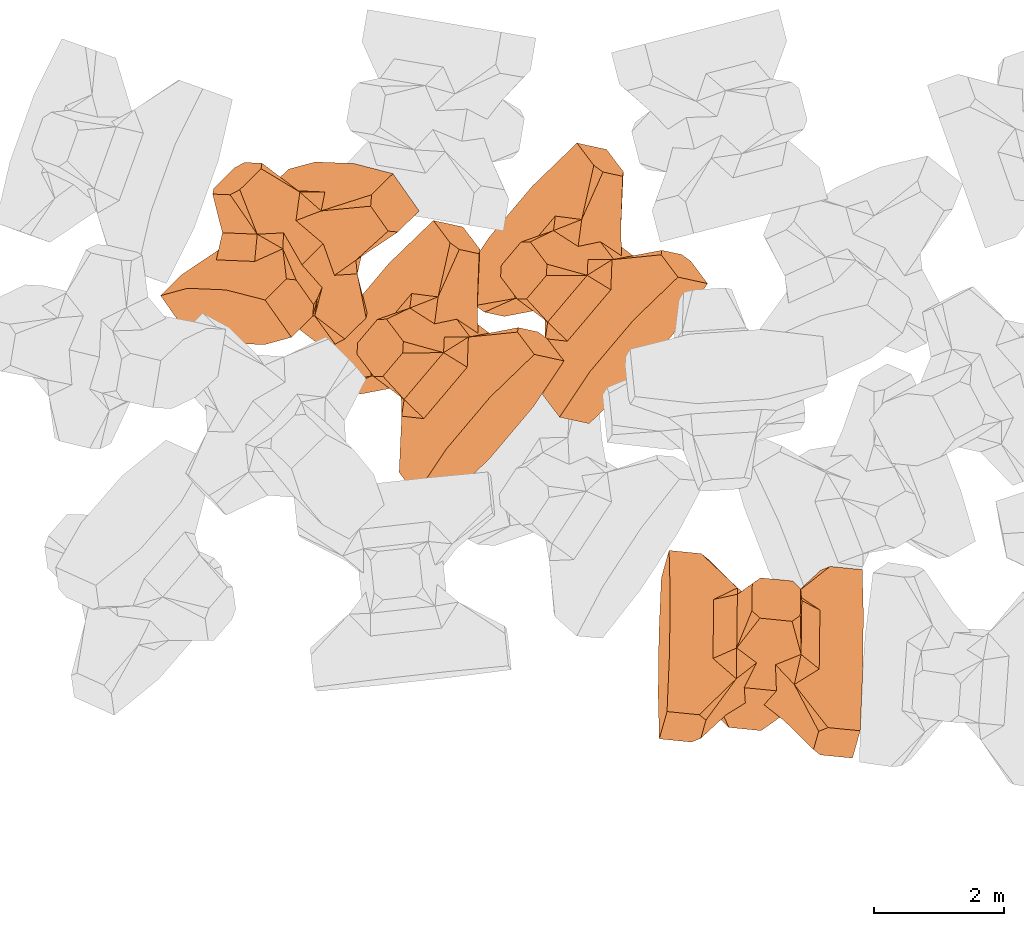
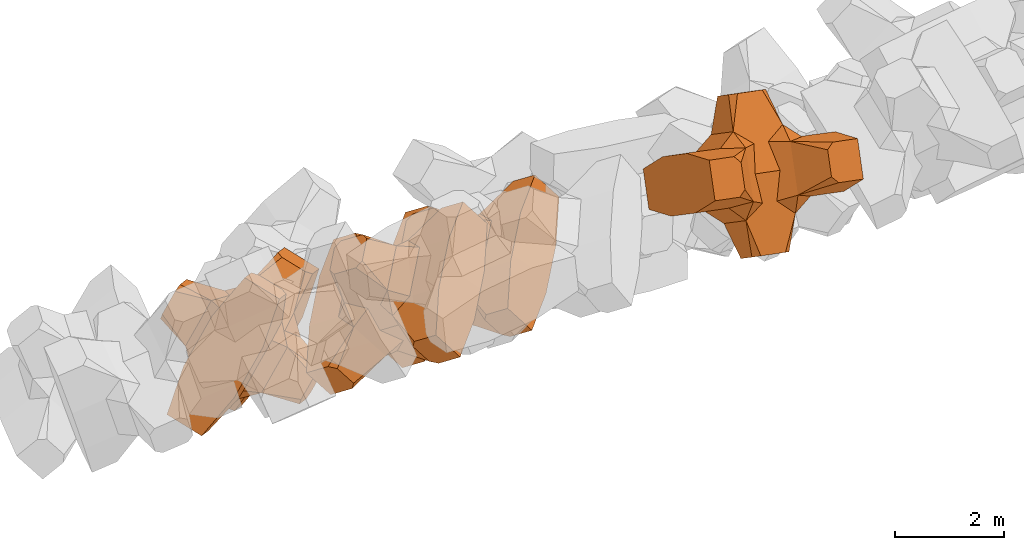
# One storey, part 12 of 17: 4 civil elements.
"""IFC4 building model written with IfcOpenShell, lengths in metres."""

from ifc_helpers import new_model, entity, si_unit, converted_unit, frame, origin_with_axes, origin_2d_with_axis, place, context, subcontext, project, spatial, polygons, element, save


model = new_model("IFC4")

# Units and contexts
model_context = context("Model", 3, precision=1e-05, world=origin_with_axes())
plan_context = context("Plan", 2, precision=1e-05, world=origin_2d_with_axis())
body_context = subcontext(model_context, "Body", "Model", "MODEL_VIEW")
ifc_project = project(units=[si_unit("VOLUMEUNIT", "CUBIC_METRE"), si_unit("LENGTHUNIT", "METRE"), converted_unit("PLANEANGLEUNIT", "degree", entity("IfcReal", 0.0174532925199433), si_unit("PLANEANGLEUNIT", "RADIAN"), dimensions=[0, 0, 0, 0, 0, 0, 0]), si_unit("AREAUNIT", "SQUARE_METRE")], contexts=[model_context, plan_context])

# Site, building, storey
site_placement = place(None, origin_with_axes())
site = spatial("IfcSite", under=ifc_project, at=site_placement)
building_placement = place(site_placement, origin_with_axes())
building = spatial("IfcBuilding", under=site, at=building_placement, Name="Building")
storey_placement = place(building_placement, origin_with_axes())
storey = spatial("IfcBuildingStorey", under=building, at=storey_placement, Name="Storey")

# Civil elements
civil_element_1_placement = place(storey_placement, frame((3.9119188785553, 18.5818061828613, 3.0172381401062), z_axis=(0.536796321599093, -0.763146803742509, -0.359800868613843), x_axis=(-0.534454296596476, 0.0224108085713021, -0.844900207426147)))
element("IfcCivilElement", 1, at=civil_element_1_placement, inside=storey, ObjectType="IfcCivilElementType", context=body_context, shape_type="Tessellation", body=[
    polygons([(0.50000011920929, 0.500000059604645, 0.821428716182709), (0.374999821186066, 0.249999940395355, 1.50000023841858), (0.550000011920929, 0.145680621266365, 0.550000131130219), (0.374999821186066, -0.250000029802322, 1.50000023841858), (0.651315808296204, -0.250000029802322, 1.45970560083697e-07), (0.651315808296204, 0.249999940395355, 1.45970560083697e-07), (0.550000011920929, -0.145680695772171, 0.550000131130219), (0.50000011920929, -0.500000059604645, 0.821428716182709), (-0.25, 0.374999791383743, 1.50000023841858), (0.249999970197678, 0.374999791383743, 1.50000023841858), (-0.500000059604645, 0.500000059604645, 0.821428716182709), (-0.550000011920929, 0.824999988079071, 0.550000131130219), (0.550000011920929, 0.824999988079071, 0.550000131130219), (-0.550000011920929, 1.5, 0.550000131130219), (0.550000011920929, 1.5, 0.550000131130219), (-0.25, -0.375, 1.50000023841858), (0.249999970197678, -0.375, 1.50000023841858), (-0.374999970197678, -0.250000029802322, 1.50000023841858), (-0.374999970197678, 0.249999940395355, 1.50000023841858), (1.5, 0.87499988079071, -0.249999836087227), (1.5, 0.87499988079071, 0.25000011920929), (0.845557510852814, 0.449999898672104, -0.49555516242981), (0.845557510852814, 0.449999898672104, 0.49555516242981), (1.5, 1.5, -0.374999821186066), (1.5, 1.5, 0.374999970197678), (1.5, 1.0, -0.374999821186066), (1.5, 1.0, 0.374999970197678), (-1.5, 1.5, -0.374999821186066), (-1.5, 1.5, 0.374999970197678), (-0.550000011920929, 1.5, -0.549999833106995), (0.550000011920929, 1.5, -0.549999833106995), (0.550000011920929, 0.145680621266365, -0.549999833106995), (-0.500000059604645, -0.500000059604645, 0.821428716182709), (-0.550000011920929, -0.145680695772171, 0.550000131130219), (-0.651315808296204, 0.249999940395355, 1.45970560083697e-07), (-0.651315808296204, -0.250000029802322, 1.45970560083697e-07), (-0.550000011920929, 0.145680621266365, 0.550000131130219), (-1.5, 0.87499988079071, 0.25000011920929), (-1.5, 0.87499988079071, -0.249999836087227), (-0.845557391643524, 0.449999898672104, 0.49555516242981), (-0.845557391643524, 0.449999898672104, -0.49555516242981), (-1.5, 1.0, 0.374999970197678), (-1.5, 1.0, -0.374999821186066), (-0.550000011920929, 0.145680621266365, -0.549999833106995), (0.550000011920929, -0.825000107288361, 0.550000131130219), (-0.550000011920929, -0.825000107288361, 0.550000131130219), (0.550000011920929, -1.5, 0.550000131130219), (-0.550000011920929, -1.5, 0.550000131130219), (1.5, -0.875000059604645, 0.25000011920929), (1.5, -0.875000059604645, -0.249999836087227), (0.845557510852814, -0.450000137090683, 0.49555516242981), (0.845557510852814, -0.450000137090683, -0.49555516242981), (1.5, -1.5, 0.374999970197678), (1.5, -1.5, -0.374999821186066), (1.5, -1.00000011920929, 0.374999970197678), (1.5, -1.00000011920929, -0.374999821186066), (0.550000011920929, -1.5, -0.549999833106995), (-0.550000011920929, -1.5, -0.549999833106995), (-1.5, -1.5, -0.374999821186066), (-1.5, -1.5, 0.374999970197678), (0.550000011920929, -0.145680695772171, -0.549999833106995), (-1.5, -0.875000059604645, -0.249999836087227), (-1.5, -0.875000059604645, 0.25000011920929), (-0.845557391643524, -0.450000137090683, -0.49555516242981), (-0.845557391643524, -0.450000137090683, 0.49555516242981), (-1.5, -1.00000011920929, -0.374999821186066), (-1.5, -1.00000011920929, 0.374999970197678), (-0.550000011920929, -0.145680695772171, -0.549999833106995), (0.50000011920929, -0.500000059604645, -0.821428537368774), (0.374999821186066, -0.250000029802322, -1.49999988079071), (0.374999821186066, 0.249999940395355, -1.49999988079071), (0.50000011920929, 0.500000059604645, -0.821428537368774), (0.249999970197678, 0.374999791383743, -1.49999988079071), (-0.25, 0.374999791383743, -1.49999988079071), (-0.500000059604645, 0.500000059604645, -0.821428537368774), (0.550000011920929, 0.824999988079071, -0.549999833106995), (-0.550000011920929, 0.824999988079071, -0.549999833106995), (0.249999970197678, -0.375, -1.49999988079071), (-0.25, -0.375, -1.49999988079071), (-0.374999970197678, -0.250000029802322, -1.49999988079071), (-0.374999970197678, 0.249999940395355, -1.49999988079071), (-0.500000059604645, -0.500000059604645, -0.821428537368774), (-0.550000011920929, -0.825000107288361, -0.549999833106995), (0.550000011920929, -0.825000107288361, -0.549999833106995)], [[[1, 2, 3]], [[3, 2, 4]], [[5, 6, 7]], [[7, 6, 3]], [[7, 3, 8]], [[8, 3, 4]], [[9, 10, 11]], [[11, 10, 1]], [[12, 13, 14]], [[14, 13, 15]], [[16, 17, 18]], [[18, 17, 4]], [[18, 4, 19]], [[19, 4, 2]], [[19, 2, 9]], [[9, 2, 10]], [[20, 21, 22]], [[22, 21, 23]], [[24, 25, 26]], [[26, 25, 27]], [[26, 27, 20]], [[20, 27, 21]], [[23, 27, 13]], [[13, 27, 25]], [[13, 25, 15]], [[28, 29, 30]], [[30, 29, 14]], [[30, 14, 31]], [[31, 14, 15]], [[31, 15, 24]], [[24, 15, 25]], [[21, 27, 23]], [[2, 1, 10]], [[13, 12, 1]], [[1, 12, 11]], [[13, 1, 23]], [[32, 22, 6]], [[6, 22, 23]], [[6, 23, 3]], [[3, 23, 1]], [[33, 18, 34]], [[34, 18, 19]], [[35, 36, 37]], [[37, 36, 34]], [[37, 34, 11]], [[11, 34, 19]], [[38, 39, 40]], [[40, 39, 41]], [[29, 28, 42]], [[42, 28, 43]], [[42, 43, 38]], [[38, 43, 39]], [[14, 29, 12]], [[12, 29, 42]], [[12, 42, 40]], [[40, 42, 38]], [[9, 11, 19]], [[40, 11, 12]], [[37, 40, 35]], [[35, 40, 41]], [[35, 41, 44]], [[11, 40, 37]], [[17, 16, 8]], [[8, 16, 33]], [[45, 46, 47]], [[47, 46, 48]], [[49, 50, 51]], [[51, 50, 52]], [[53, 54, 55]], [[55, 54, 56]], [[55, 56, 49]], [[49, 56, 50]], [[47, 53, 45]], [[45, 53, 55]], [[45, 55, 51]], [[54, 53, 57]], [[57, 53, 47]], [[57, 47, 58]], [[58, 47, 48]], [[58, 48, 59]], [[59, 48, 60]], [[51, 55, 49]], [[17, 8, 4]], [[46, 45, 33]], [[33, 45, 8]], [[51, 8, 45]], [[7, 51, 5]], [[5, 51, 52]], [[5, 52, 61]], [[8, 51, 7]], [[62, 63, 64]], [[64, 63, 65]], [[59, 60, 66]], [[66, 60, 67]], [[66, 67, 62]], [[62, 67, 63]], [[65, 67, 46]], [[46, 67, 60]], [[46, 60, 48]], [[63, 67, 65]], [[18, 33, 16]], [[46, 33, 65]], [[68, 64, 36]], [[36, 64, 65]], [[36, 65, 34]], [[34, 65, 33]], [[69, 70, 61]], [[61, 70, 71]], [[6, 5, 32]], [[32, 5, 61]], [[32, 61, 72]], [[72, 61, 71]], [[73, 74, 72]], [[72, 74, 75]], [[76, 77, 31]], [[31, 77, 30]], [[78, 79, 70]], [[70, 79, 80]], [[70, 80, 71]], [[71, 80, 81]], [[71, 81, 73]], [[73, 81, 74]], [[31, 24, 76]], [[76, 24, 26]], [[76, 26, 22]], [[22, 26, 20]], [[73, 72, 71]], [[77, 76, 75]], [[75, 76, 72]], [[22, 72, 76]], [[72, 22, 32]], [[75, 81, 44]], [[44, 81, 80]], [[36, 35, 68]], [[68, 35, 44]], [[68, 44, 82]], [[82, 44, 80]], [[41, 43, 77]], [[77, 43, 28]], [[77, 28, 30]], [[39, 43, 41]], [[81, 75, 74]], [[77, 75, 41]], [[44, 41, 75]], [[79, 78, 82]], [[82, 78, 69]], [[83, 84, 58]], [[58, 84, 57]], [[52, 56, 84]], [[84, 56, 54]], [[84, 54, 57]], [[50, 56, 52]], [[70, 69, 78]], [[84, 83, 69]], [[69, 83, 82]], [[84, 69, 52]], [[61, 52, 69]], [[58, 59, 83]], [[83, 59, 66]], [[83, 66, 64]], [[64, 66, 62]], [[79, 82, 80]], [[64, 82, 83]], [[82, 64, 68]]], closed=True),
])
civil_element_2_placement = place(storey_placement, frame((8.40735340118408, 18.1207790374756, 3.29278421401978), z_axis=(0.605860889445885, -0.131685242162894, -0.784596443808115), x_axis=(0.605345729447791, 0.716229860077992, 0.34723383385261)))
element("IfcCivilElement", 2, at=civil_element_2_placement, inside=storey, ObjectType="IfcCivilElementType", context=body_context, shape_type="Tessellation", body=[
    polygons([(0.500000178813934, 0.500001192092896, 0.821429014205933), (0.374999850988388, 0.250000506639481, 1.50000059604645), (0.550000071525574, 0.145680949091911, 0.550000309944153), (0.374999850988388, -0.250000566244125, 1.50000059604645), (0.651315867900848, -0.250000566244125, 1.45970602716261e-07), (0.651315867900848, 0.250000506639481, 1.45970602716261e-07), (0.550000071525574, -0.145681023597717, 0.550000309944153), (0.500000178813934, -0.500001192092896, 0.821429014205933), (-0.250000029802322, 0.37500062584877, 1.50000059604645), (0.249999985098839, 0.37500062584877, 1.50000059604645), (-0.500000059604645, 0.500001192092896, 0.821429014205933), (-0.550000071525574, 0.825001835823059, 0.550000309944153), (0.550000071525574, 0.825001835823059, 0.550000309944153), (-0.550000071525574, 1.5000034570694, 0.550000309944153), (0.550000071525574, 1.5000034570694, 0.550000309944153), (-0.250000029802322, -0.375000864267349, 1.50000059604645), (0.249999985098839, -0.375000864267349, 1.50000059604645), (-0.375, -0.250000566244125, 1.50000059604645), (-0.375, 0.250000506639481, 1.50000059604645), (1.50000023841858, 0.875001847743988, -0.249999910593033), (1.50000023841858, 0.875001847743988, 0.250000208616257), (0.845557630062103, 0.450000911951065, -0.495555311441422), (0.845557630062103, 0.450000911951065, 0.495555311441422), (1.50000023841858, 1.5000034570694, -0.374999940395355), (1.50000023841858, 1.5000034570694, 0.375000089406967), (1.50000023841858, 1.0000022649765, -0.374999940395355), (1.50000023841858, 1.0000022649765, 0.375000089406967), (-1.50000023841858, 1.5000034570694, -0.374999940395355), (-1.50000023841858, 1.5000034570694, 0.375000089406967), (-0.550000071525574, 1.5000034570694, -0.550000011920929), (0.550000071525574, 1.5000034570694, -0.550000011920929), (0.550000071525574, 0.145680949091911, -0.550000011920929), (-0.500000059604645, -0.500001192092896, 0.821429014205933), (-0.550000071525574, -0.145681023597717, 0.550000309944153), (-0.651315867900848, 0.250000506639481, 1.45970602716261e-07), (-0.651315867900848, -0.250000566244125, 1.45970602716261e-07), (-0.550000071525574, 0.145680949091911, 0.550000309944153), (-1.50000023841858, 0.875001847743988, 0.250000208616257), (-1.50000023841858, 0.875001847743988, -0.249999910593033), (-0.845557451248169, 0.450000911951065, 0.495555311441422), (-0.845557451248169, 0.450000911951065, -0.495555311441422), (-1.50000023841858, 1.0000022649765, 0.375000089406967), (-1.50000023841858, 1.0000022649765, -0.374999940395355), (-0.550000071525574, 0.145680949091911, -0.550000011920929), (0.550000071525574, -0.825001955032349, 0.550000309944153), (-0.550000071525574, -0.825001955032349, 0.550000309944153), (0.550000071525574, -1.5000034570694, 0.550000309944153), (-0.550000071525574, -1.5000034570694, 0.550000309944153), (1.50000023841858, -0.875002026557922, 0.250000208616257), (1.50000023841858, -0.875002026557922, -0.249999910593033), (0.845557630062103, -0.450001120567322, 0.495555311441422), (0.845557630062103, -0.450001120567322, -0.495555311441422), (1.50000023841858, -1.5000034570694, 0.375000089406967), (1.50000023841858, -1.5000034570694, -0.374999940395355), (1.50000023841858, -1.00000238418579, 0.375000089406967), (1.50000023841858, -1.00000238418579, -0.374999940395355), (0.550000071525574, -1.5000034570694, -0.550000011920929), (-0.550000071525574, -1.5000034570694, -0.550000011920929), (-1.50000023841858, -1.5000034570694, -0.374999940395355), (-1.50000023841858, -1.5000034570694, 0.375000089406967), (0.550000071525574, -0.145681023597717, -0.550000011920929), (-1.50000023841858, -0.875002026557922, -0.249999910593033), (-1.50000023841858, -0.875002026557922, 0.250000208616257), (-0.845557451248169, -0.450001120567322, -0.495555311441422), (-0.845557451248169, -0.450001120567322, 0.495555311441422), (-1.50000023841858, -1.00000238418579, -0.374999940395355), (-1.50000023841858, -1.00000238418579, 0.375000089406967), (-0.550000071525574, -0.145681023597717, -0.550000011920929), (0.500000178813934, -0.500001192092896, -0.821428775787354), (0.374999850988388, -0.250000566244125, -1.50000035762787), (0.374999850988388, 0.250000506639481, -1.50000035762787), (0.500000178813934, 0.500001192092896, -0.821428775787354), (0.249999985098839, 0.37500062584877, -1.50000035762787), (-0.250000029802322, 0.37500062584877, -1.50000035762787), (-0.500000059604645, 0.500001192092896, -0.821428775787354), (0.550000071525574, 0.825001835823059, -0.550000011920929), (-0.550000071525574, 0.825001835823059, -0.550000011920929), (0.249999985098839, -0.375000864267349, -1.50000035762787), (-0.250000029802322, -0.375000864267349, -1.50000035762787), (-0.375, -0.250000566244125, -1.50000035762787), (-0.375, 0.250000506639481, -1.50000035762787), (-0.500000059604645, -0.500001192092896, -0.821428775787354), (-0.550000071525574, -0.825001955032349, -0.550000011920929), (0.550000071525574, -0.825001955032349, -0.550000011920929)], [[[1, 2, 3]], [[3, 2, 4]], [[5, 6, 7]], [[7, 6, 3]], [[7, 3, 8]], [[8, 3, 4]], [[9, 10, 11]], [[11, 10, 1]], [[12, 13, 14]], [[14, 13, 15]], [[16, 17, 18]], [[18, 17, 4]], [[18, 4, 19]], [[19, 4, 2]], [[19, 2, 9]], [[9, 2, 10]], [[20, 21, 22]], [[22, 21, 23]], [[24, 25, 26]], [[26, 25, 27]], [[26, 27, 20]], [[20, 27, 21]], [[23, 27, 13]], [[13, 27, 25]], [[13, 25, 15]], [[28, 29, 30]], [[30, 29, 14]], [[30, 14, 31]], [[31, 14, 15]], [[31, 15, 24]], [[24, 15, 25]], [[21, 27, 23]], [[2, 1, 10]], [[13, 12, 1]], [[1, 12, 11]], [[13, 1, 23]], [[32, 22, 6]], [[6, 22, 23]], [[6, 23, 3]], [[3, 23, 1]], [[33, 18, 34]], [[34, 18, 19]], [[35, 36, 37]], [[37, 36, 34]], [[37, 34, 11]], [[11, 34, 19]], [[38, 39, 40]], [[40, 39, 41]], [[29, 28, 42]], [[42, 28, 43]], [[42, 43, 38]], [[38, 43, 39]], [[14, 29, 12]], [[12, 29, 42]], [[12, 42, 40]], [[40, 42, 38]], [[9, 11, 19]], [[40, 11, 12]], [[37, 40, 35]], [[35, 40, 41]], [[35, 41, 44]], [[11, 40, 37]], [[17, 16, 8]], [[8, 16, 33]], [[45, 46, 47]], [[47, 46, 48]], [[49, 50, 51]], [[51, 50, 52]], [[53, 54, 55]], [[55, 54, 56]], [[55, 56, 49]], [[49, 56, 50]], [[47, 53, 45]], [[45, 53, 55]], [[45, 55, 51]], [[54, 53, 57]], [[57, 53, 47]], [[57, 47, 58]], [[58, 47, 48]], [[58, 48, 59]], [[59, 48, 60]], [[51, 55, 49]], [[17, 8, 4]], [[46, 45, 33]], [[33, 45, 8]], [[51, 8, 45]], [[7, 51, 5]], [[5, 51, 52]], [[5, 52, 61]], [[8, 51, 7]], [[62, 63, 64]], [[64, 63, 65]], [[59, 60, 66]], [[66, 60, 67]], [[66, 67, 62]], [[62, 67, 63]], [[65, 67, 46]], [[46, 67, 60]], [[46, 60, 48]], [[63, 67, 65]], [[18, 33, 16]], [[46, 33, 65]], [[68, 64, 36]], [[36, 64, 65]], [[36, 65, 34]], [[34, 65, 33]], [[69, 70, 61]], [[61, 70, 71]], [[6, 5, 32]], [[32, 5, 61]], [[32, 61, 72]], [[72, 61, 71]], [[73, 74, 72]], [[72, 74, 75]], [[76, 77, 31]], [[31, 77, 30]], [[78, 79, 70]], [[70, 79, 80]], [[70, 80, 71]], [[71, 80, 81]], [[71, 81, 73]], [[73, 81, 74]], [[31, 24, 76]], [[76, 24, 26]], [[76, 26, 22]], [[22, 26, 20]], [[73, 72, 71]], [[77, 76, 75]], [[75, 76, 72]], [[22, 72, 76]], [[72, 22, 32]], [[75, 81, 44]], [[44, 81, 80]], [[36, 35, 68]], [[68, 35, 44]], [[68, 44, 82]], [[82, 44, 80]], [[41, 43, 77]], [[77, 43, 28]], [[77, 28, 30]], [[39, 43, 41]], [[81, 75, 74]], [[77, 75, 41]], [[44, 41, 75]], [[79, 78, 82]], [[82, 78, 69]], [[83, 84, 58]], [[58, 84, 57]], [[52, 56, 84]], [[84, 56, 54]], [[84, 54, 57]], [[50, 56, 52]], [[70, 69, 78]], [[84, 83, 69]], [[69, 83, 82]], [[84, 69, 52]], [[61, 52, 69]], [[58, 59, 83]], [[83, 59, 66]], [[83, 66, 64]], [[64, 66, 62]], [[79, 82, 80]], [[64, 82, 83]], [[82, 64, 68]]], closed=True),
])
civil_element_3_placement = place(storey_placement, frame((6.20587396621704, 16.93332862854, 4.18438720703125), z_axis=(0.606335459487333, -0.132312357065121, -0.784124193438869), x_axis=(0.604869783486197, 0.71686023540291, 0.346762091243327)))
element("IfcCivilElement", 3, at=civil_element_3_placement, inside=storey, ObjectType="IfcCivilElementType", context=body_context, shape_type="Tessellation", body=[
    polygons([(0.500000178813934, 0.500000178813934, 0.821428716182709), (0.374999850988388, 0.25, 1.50000023841858), (0.550000071525574, 0.145680651068687, 0.550000131130219), (0.374999850988388, -0.250000059604645, 1.50000023841858), (0.651315867900848, -0.250000059604645, 1.45970560083697e-07), (0.651315867900848, 0.25, 1.45970560083697e-07), (0.550000071525574, -0.145680725574493, 0.550000131130219), (0.500000178813934, -0.500000178813934, 0.821428716182709), (-0.250000029802322, 0.374999850988388, 1.50000023841858), (0.249999985098839, 0.374999850988388, 1.50000023841858), (-0.500000059604645, 0.500000178813934, 0.821428716182709), (-0.550000071525574, 0.825000166893005, 0.550000131130219), (0.550000071525574, 0.825000166893005, 0.550000131130219), (-0.550000071525574, 1.50000035762787, 0.550000131130219), (0.550000071525574, 1.50000035762787, 0.550000131130219), (-0.250000029802322, -0.375000089406967, 1.50000023841858), (0.249999985098839, -0.375000089406967, 1.50000023841858), (-0.375, -0.250000059604645, 1.50000023841858), (-0.375, 0.25, 1.50000023841858), (1.50000023841858, 0.875000059604645, -0.249999836087227), (1.50000023841858, 0.875000059604645, 0.25000011920929), (0.845557630062103, 0.449999988079071, -0.49555516242981), (0.845557630062103, 0.449999988079071, 0.49555516242981), (1.50000023841858, 1.50000035762787, -0.374999821186066), (1.50000023841858, 1.50000035762787, 0.374999970197678), (1.50000023841858, 1.00000023841858, -0.374999821186066), (1.50000023841858, 1.00000023841858, 0.374999970197678), (-1.50000023841858, 1.50000035762787, -0.374999821186066), (-1.50000023841858, 1.50000035762787, 0.374999970197678), (-0.550000071525574, 1.50000035762787, -0.549999833106995), (0.550000071525574, 1.50000035762787, -0.549999833106995), (0.550000071525574, 0.145680651068687, -0.549999833106995), (-0.500000059604645, -0.500000178813934, 0.821428716182709), (-0.550000071525574, -0.145680725574493, 0.550000131130219), (-0.651315867900848, 0.25, 1.45970560083697e-07), (-0.651315867900848, -0.250000059604645, 1.45970560083697e-07), (-0.550000071525574, 0.145680651068687, 0.550000131130219), (-1.50000023841858, 0.875000059604645, 0.25000011920929), (-1.50000023841858, 0.875000059604645, -0.249999836087227), (-0.845557451248169, 0.449999988079071, 0.49555516242981), (-0.845557451248169, 0.449999988079071, -0.49555516242981), (-1.50000023841858, 1.00000023841858, 0.374999970197678), (-1.50000023841858, 1.00000023841858, -0.374999821186066), (-0.550000071525574, 0.145680651068687, -0.549999833106995), (0.550000071525574, -0.825000286102295, 0.550000131130219), (-0.550000071525574, -0.825000286102295, 0.550000131130219), (0.550000071525574, -1.50000035762787, 0.550000131130219), (-0.550000071525574, -1.50000035762787, 0.550000131130219), (1.50000023841858, -0.875000238418579, 0.25000011920929), (1.50000023841858, -0.875000238418579, -0.249999836087227), (0.845557630062103, -0.450000196695328, 0.49555516242981), (0.845557630062103, -0.450000196695328, -0.49555516242981), (1.50000023841858, -1.50000035762787, 0.374999970197678), (1.50000023841858, -1.50000035762787, -0.374999821186066), (1.50000023841858, -1.00000035762787, 0.374999970197678), (1.50000023841858, -1.00000035762787, -0.374999821186066), (0.550000071525574, -1.50000035762787, -0.549999833106995), (-0.550000071525574, -1.50000035762787, -0.549999833106995), (-1.50000023841858, -1.50000035762787, -0.374999821186066), (-1.50000023841858, -1.50000035762787, 0.374999970197678), (0.550000071525574, -0.145680725574493, -0.549999833106995), (-1.50000023841858, -0.875000238418579, -0.249999836087227), (-1.50000023841858, -0.875000238418579, 0.25000011920929), (-0.845557451248169, -0.450000196695328, -0.49555516242981), (-0.845557451248169, -0.450000196695328, 0.49555516242981), (-1.50000023841858, -1.00000035762787, -0.374999821186066), (-1.50000023841858, -1.00000035762787, 0.374999970197678), (-0.550000071525574, -0.145680725574493, -0.549999833106995), (0.500000178813934, -0.500000178813934, -0.821428537368774), (0.374999850988388, -0.250000059604645, -1.49999988079071), (0.374999850988388, 0.25, -1.49999988079071), (0.500000178813934, 0.500000178813934, -0.821428537368774), (0.249999985098839, 0.374999850988388, -1.49999988079071), (-0.250000029802322, 0.374999850988388, -1.49999988079071), (-0.500000059604645, 0.500000178813934, -0.821428537368774), (0.550000071525574, 0.825000166893005, -0.549999833106995), (-0.550000071525574, 0.825000166893005, -0.549999833106995), (0.249999985098839, -0.375000089406967, -1.49999988079071), (-0.250000029802322, -0.375000089406967, -1.49999988079071), (-0.375, -0.250000059604645, -1.49999988079071), (-0.375, 0.25, -1.49999988079071), (-0.500000059604645, -0.500000178813934, -0.821428537368774), (-0.550000071525574, -0.825000286102295, -0.549999833106995), (0.550000071525574, -0.825000286102295, -0.549999833106995)], [[[1, 2, 3]], [[3, 2, 4]], [[5, 6, 7]], [[7, 6, 3]], [[7, 3, 8]], [[8, 3, 4]], [[9, 10, 11]], [[11, 10, 1]], [[12, 13, 14]], [[14, 13, 15]], [[16, 17, 18]], [[18, 17, 4]], [[18, 4, 19]], [[19, 4, 2]], [[19, 2, 9]], [[9, 2, 10]], [[20, 21, 22]], [[22, 21, 23]], [[24, 25, 26]], [[26, 25, 27]], [[26, 27, 20]], [[20, 27, 21]], [[23, 27, 13]], [[13, 27, 25]], [[13, 25, 15]], [[28, 29, 30]], [[30, 29, 14]], [[30, 14, 31]], [[31, 14, 15]], [[31, 15, 24]], [[24, 15, 25]], [[21, 27, 23]], [[2, 1, 10]], [[13, 12, 1]], [[1, 12, 11]], [[13, 1, 23]], [[32, 22, 6]], [[6, 22, 23]], [[6, 23, 3]], [[3, 23, 1]], [[33, 18, 34]], [[34, 18, 19]], [[35, 36, 37]], [[37, 36, 34]], [[37, 34, 11]], [[11, 34, 19]], [[38, 39, 40]], [[40, 39, 41]], [[29, 28, 42]], [[42, 28, 43]], [[42, 43, 38]], [[38, 43, 39]], [[14, 29, 12]], [[12, 29, 42]], [[12, 42, 40]], [[40, 42, 38]], [[9, 11, 19]], [[40, 11, 12]], [[37, 40, 35]], [[35, 40, 41]], [[35, 41, 44]], [[11, 40, 37]], [[17, 16, 8]], [[8, 16, 33]], [[45, 46, 47]], [[47, 46, 48]], [[49, 50, 51]], [[51, 50, 52]], [[53, 54, 55]], [[55, 54, 56]], [[55, 56, 49]], [[49, 56, 50]], [[47, 53, 45]], [[45, 53, 55]], [[45, 55, 51]], [[54, 53, 57]], [[57, 53, 47]], [[57, 47, 58]], [[58, 47, 48]], [[58, 48, 59]], [[59, 48, 60]], [[51, 55, 49]], [[17, 8, 4]], [[46, 45, 33]], [[33, 45, 8]], [[51, 8, 45]], [[7, 51, 5]], [[5, 51, 52]], [[5, 52, 61]], [[8, 51, 7]], [[62, 63, 64]], [[64, 63, 65]], [[59, 60, 66]], [[66, 60, 67]], [[66, 67, 62]], [[62, 67, 63]], [[65, 67, 46]], [[46, 67, 60]], [[46, 60, 48]], [[63, 67, 65]], [[18, 33, 16]], [[46, 33, 65]], [[68, 64, 36]], [[36, 64, 65]], [[36, 65, 34]], [[34, 65, 33]], [[69, 70, 61]], [[61, 70, 71]], [[6, 5, 32]], [[32, 5, 61]], [[32, 61, 72]], [[72, 61, 71]], [[73, 74, 72]], [[72, 74, 75]], [[76, 77, 31]], [[31, 77, 30]], [[78, 79, 70]], [[70, 79, 80]], [[70, 80, 71]], [[71, 80, 81]], [[71, 81, 73]], [[73, 81, 74]], [[31, 24, 76]], [[76, 24, 26]], [[76, 26, 22]], [[22, 26, 20]], [[73, 72, 71]], [[77, 76, 75]], [[75, 76, 72]], [[22, 72, 76]], [[72, 22, 32]], [[75, 81, 44]], [[44, 81, 80]], [[36, 35, 68]], [[68, 35, 44]], [[68, 44, 82]], [[82, 44, 80]], [[41, 43, 77]], [[77, 43, 28]], [[77, 28, 30]], [[39, 43, 41]], [[81, 75, 74]], [[77, 75, 41]], [[44, 41, 75]], [[79, 78, 82]], [[82, 78, 69]], [[83, 84, 58]], [[58, 84, 57]], [[52, 56, 84]], [[84, 56, 54]], [[84, 54, 57]], [[50, 56, 52]], [[70, 69, 78]], [[84, 83, 69]], [[69, 83, 82]], [[84, 69, 52]], [[61, 52, 69]], [[58, 59, 83]], [[83, 59, 66]], [[83, 66, 64]], [[64, 66, 62]], [[79, 82, 80]], [[64, 82, 83]], [[82, 64, 68]]], closed=True),
])
civil_element_4_placement = place(storey_placement, frame((11.1320972442627, 12.4339904785156, 7.96058797836304), z_axis=(0.158190593261545, 0.558668256293717, 0.81416553329977), x_axis=(-0.0105157165007177, -0.823547812121221, 0.567149381430348)))
element("IfcCivilElement", 4, at=civil_element_4_placement, inside=storey, ObjectType="IfcCivilElementType", context=body_context, shape_type="Tessellation", body=[
    polygons([(0.500000715255737, 0.500000476837158, 0.821428716182709), (0.375000268220901, 0.250000149011612, 1.50000023841858), (0.550000607967377, 0.145680740475655, 0.550000131130219), (0.375000268220901, -0.250000208616257, 1.50000023841858), (0.651316583156586, -0.250000208616257, 1.45970560083697e-07), (0.651316583156586, 0.250000149011612, 1.45970560083697e-07), (0.550000607967377, -0.145680814981461, 0.550000131130219), (0.500000715255737, -0.500000476837158, 0.821428716182709), (-0.250000298023224, 0.375000089406967, 1.50000023841858), (0.250000268220901, 0.375000089406967, 1.50000023841858), (-0.500000596046448, 0.500000476837158, 0.821428716182709), (-0.550000607967377, 0.825000643730164, 0.550000131130219), (0.550000607967377, 0.825000643730164, 0.550000131130219), (-0.550000607967377, 1.5000011920929, 0.550000131130219), (0.550000607967377, 1.5000011920929, 0.550000131130219), (-0.250000298023224, -0.375000298023224, 1.50000023841858), (0.250000268220901, -0.375000298023224, 1.50000023841858), (-0.375000417232513, -0.250000208616257, 1.50000023841858), (-0.375000417232513, 0.250000149011612, 1.50000023841858), (1.50000178813934, 0.875000536441803, -0.249999836087227), (1.50000178813934, 0.875000536441803, 0.25000011920929), (0.845558524131775, 0.450000256299973, -0.49555516242981), (0.845558524131775, 0.450000256299973, 0.49555516242981), (1.50000178813934, 1.5000011920929, -0.374999821186066), (1.50000178813934, 1.5000011920929, 0.374999970197678), (1.50000178813934, 1.00000083446503, -0.374999821186066), (1.50000178813934, 1.00000083446503, 0.374999970197678), (-1.50000178813934, 1.5000011920929, -0.374999821186066), (-1.50000178813934, 1.5000011920929, 0.374999970197678), (-0.550000607967377, 1.5000011920929, -0.549999833106995), (0.550000607967377, 1.5000011920929, -0.549999833106995), (0.550000607967377, 0.145680740475655, -0.549999833106995), (-0.500000596046448, -0.500000476837158, 0.821428716182709), (-0.550000607967377, -0.145680814981461, 0.550000131130219), (-0.651316583156586, 0.250000149011612, 1.45970560083697e-07), (-0.651316583156586, -0.250000208616257, 1.45970560083697e-07), (-0.550000607967377, 0.145680740475655, 0.550000131130219), (-1.50000178813934, 0.875000536441803, 0.25000011920929), (-1.50000178813934, 0.875000536441803, -0.249999836087227), (-0.845558345317841, 0.450000256299973, 0.49555516242981), (-0.845558345317841, 0.450000256299973, -0.49555516242981), (-1.50000178813934, 1.00000083446503, 0.374999970197678), (-1.50000178813934, 1.00000083446503, -0.374999821186066), (-0.550000607967377, 0.145680740475655, -0.549999833106995), (0.550000607967377, -0.825000762939453, 0.550000131130219), (-0.550000607967377, -0.825000762939453, 0.550000131130219), (0.550000607967377, -1.5000011920929, 0.550000131130219), (-0.550000607967377, -1.5000011920929, 0.550000131130219), (1.50000178813934, -0.875000774860382, 0.25000011920929), (1.50000178813934, -0.875000774860382, -0.249999836087227), (0.845558524131775, -0.450000464916229, 0.49555516242981), (0.845558524131775, -0.450000464916229, -0.49555516242981), (1.50000178813934, -1.5000011920929, 0.374999970197678), (1.50000178813934, -1.5000011920929, -0.374999821186066), (1.50000178813934, -1.00000095367432, 0.374999970197678), (1.50000178813934, -1.00000095367432, -0.374999821186066), (0.550000607967377, -1.5000011920929, -0.549999833106995), (-0.550000607967377, -1.5000011920929, -0.549999833106995), (-1.50000178813934, -1.5000011920929, -0.374999821186066), (-1.50000178813934, -1.5000011920929, 0.374999970197678), (0.550000607967377, -0.145680814981461, -0.549999833106995), (-1.50000178813934, -0.875000774860382, -0.249999836087227), (-1.50000178813934, -0.875000774860382, 0.25000011920929), (-0.845558345317841, -0.450000464916229, -0.49555516242981), (-0.845558345317841, -0.450000464916229, 0.49555516242981), (-1.50000178813934, -1.00000095367432, -0.374999821186066), (-1.50000178813934, -1.00000095367432, 0.374999970197678), (-0.550000607967377, -0.145680814981461, -0.549999833106995), (0.500000715255737, -0.500000476837158, -0.821428537368774), (0.375000268220901, -0.250000208616257, -1.49999988079071), (0.375000268220901, 0.250000149011612, -1.49999988079071), (0.500000715255737, 0.500000476837158, -0.821428537368774), (0.250000268220901, 0.375000089406967, -1.49999988079071), (-0.250000298023224, 0.375000089406967, -1.49999988079071), (-0.500000596046448, 0.500000476837158, -0.821428537368774), (0.550000607967377, 0.825000643730164, -0.549999833106995), (-0.550000607967377, 0.825000643730164, -0.549999833106995), (0.250000268220901, -0.375000298023224, -1.49999988079071), (-0.250000298023224, -0.375000298023224, -1.49999988079071), (-0.375000417232513, -0.250000208616257, -1.49999988079071), (-0.375000417232513, 0.250000149011612, -1.49999988079071), (-0.500000596046448, -0.500000476837158, -0.821428537368774), (-0.550000607967377, -0.825000762939453, -0.549999833106995), (0.550000607967377, -0.825000762939453, -0.549999833106995)], [[[1, 2, 3]], [[3, 2, 4]], [[5, 6, 7]], [[7, 6, 3]], [[7, 3, 8]], [[8, 3, 4]], [[9, 10, 11]], [[11, 10, 1]], [[12, 13, 14]], [[14, 13, 15]], [[16, 17, 18]], [[18, 17, 4]], [[18, 4, 19]], [[19, 4, 2]], [[19, 2, 9]], [[9, 2, 10]], [[20, 21, 22]], [[22, 21, 23]], [[24, 25, 26]], [[26, 25, 27]], [[26, 27, 20]], [[20, 27, 21]], [[23, 27, 13]], [[13, 27, 25]], [[13, 25, 15]], [[28, 29, 30]], [[30, 29, 14]], [[30, 14, 31]], [[31, 14, 15]], [[31, 15, 24]], [[24, 15, 25]], [[21, 27, 23]], [[2, 1, 10]], [[13, 12, 1]], [[1, 12, 11]], [[13, 1, 23]], [[32, 22, 6]], [[6, 22, 23]], [[6, 23, 3]], [[3, 23, 1]], [[33, 18, 34]], [[34, 18, 19]], [[35, 36, 37]], [[37, 36, 34]], [[37, 34, 11]], [[11, 34, 19]], [[38, 39, 40]], [[40, 39, 41]], [[29, 28, 42]], [[42, 28, 43]], [[42, 43, 38]], [[38, 43, 39]], [[14, 29, 12]], [[12, 29, 42]], [[12, 42, 40]], [[40, 42, 38]], [[9, 11, 19]], [[40, 11, 12]], [[37, 40, 35]], [[35, 40, 41]], [[35, 41, 44]], [[11, 40, 37]], [[17, 16, 8]], [[8, 16, 33]], [[45, 46, 47]], [[47, 46, 48]], [[49, 50, 51]], [[51, 50, 52]], [[53, 54, 55]], [[55, 54, 56]], [[55, 56, 49]], [[49, 56, 50]], [[47, 53, 45]], [[45, 53, 55]], [[45, 55, 51]], [[54, 53, 57]], [[57, 53, 47]], [[57, 47, 58]], [[58, 47, 48]], [[58, 48, 59]], [[59, 48, 60]], [[51, 55, 49]], [[17, 8, 4]], [[46, 45, 33]], [[33, 45, 8]], [[51, 8, 45]], [[7, 51, 5]], [[5, 51, 52]], [[5, 52, 61]], [[8, 51, 7]], [[62, 63, 64]], [[64, 63, 65]], [[59, 60, 66]], [[66, 60, 67]], [[66, 67, 62]], [[62, 67, 63]], [[65, 67, 46]], [[46, 67, 60]], [[46, 60, 48]], [[63, 67, 65]], [[18, 33, 16]], [[46, 33, 65]], [[68, 64, 36]], [[36, 64, 65]], [[36, 65, 34]], [[34, 65, 33]], [[69, 70, 61]], [[61, 70, 71]], [[6, 5, 32]], [[32, 5, 61]], [[32, 61, 72]], [[72, 61, 71]], [[73, 74, 72]], [[72, 74, 75]], [[76, 77, 31]], [[31, 77, 30]], [[78, 79, 70]], [[70, 79, 80]], [[70, 80, 71]], [[71, 80, 81]], [[71, 81, 73]], [[73, 81, 74]], [[31, 24, 76]], [[76, 24, 26]], [[76, 26, 22]], [[22, 26, 20]], [[73, 72, 71]], [[77, 76, 75]], [[75, 76, 72]], [[22, 72, 76]], [[72, 22, 32]], [[75, 81, 44]], [[44, 81, 80]], [[36, 35, 68]], [[68, 35, 44]], [[68, 44, 82]], [[82, 44, 80]], [[41, 43, 77]], [[77, 43, 28]], [[77, 28, 30]], [[39, 43, 41]], [[81, 75, 74]], [[77, 75, 41]], [[44, 41, 75]], [[79, 78, 82]], [[82, 78, 69]], [[83, 84, 58]], [[58, 84, 57]], [[52, 56, 84]], [[84, 56, 54]], [[84, 54, 57]], [[50, 56, 52]], [[70, 69, 78]], [[84, 83, 69]], [[69, 83, 82]], [[84, 69, 52]], [[61, 52, 69]], [[58, 59, 83]], [[83, 59, 66]], [[83, 66, 64]], [[64, 66, 62]], [[79, 82, 80]], [[64, 82, 83]], [[82, 64, 68]]], closed=True),
])

save(model, "model.ifc")
